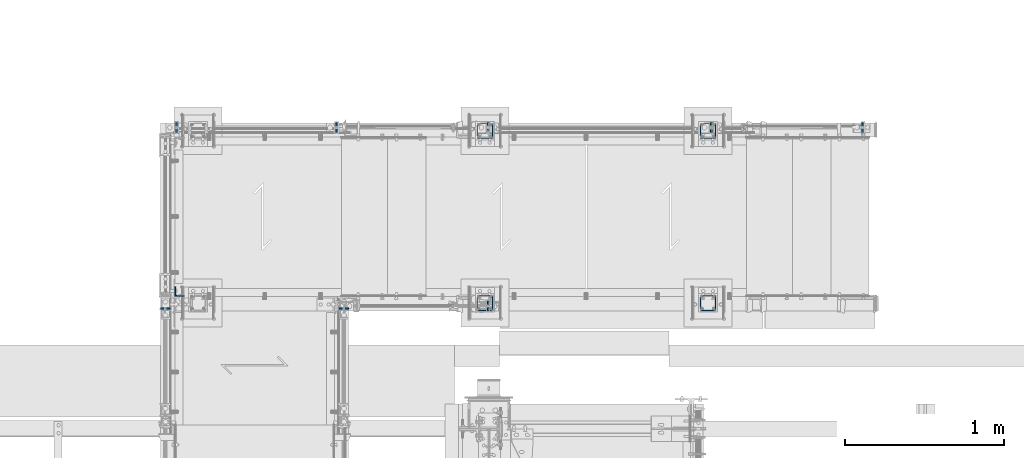
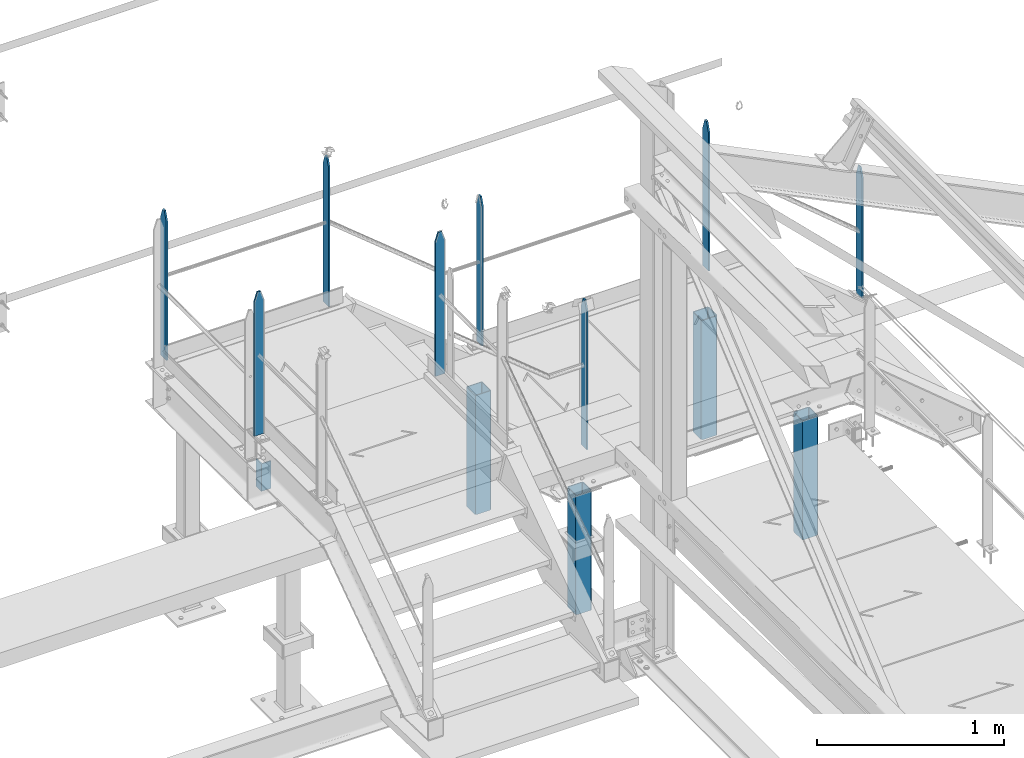
# One storey, part 40 of 496: 13 columns, 9 elements without a shape of their own.
"""IFC2X3 building model written with IfcOpenShell, lengths in millimetres."""

from ifc_helpers import new_model, si_unit, frame, origin_with_axes, origin_2d_with_axis, place, context, subcontext, project, spatial, rectangle, hollow_rectangle, l_section, extrude, clip, halfspace, material, type_object, element, aggregate, save


model = new_model("IFC2X3")

# Units and contexts
model_context = context("Model", 3, precision=1e-05, world=origin_with_axes())
body_context = subcontext(model_context, "Body", "Model", "MODEL_VIEW")
ifc_project = project(units=[si_unit("LENGTHUNIT", "METRE", prefix="MILLI"), si_unit("AREAUNIT", "SQUARE_METRE"), si_unit("VOLUMEUNIT", "CUBIC_METRE"), si_unit("MASSUNIT", "GRAM", prefix="KILO"), si_unit("TIMEUNIT", "SECOND"), si_unit("PLANEANGLEUNIT", "RADIAN"), si_unit("SOLIDANGLEUNIT", "STERADIAN"), si_unit("THERMODYNAMICTEMPERATUREUNIT", "DEGREE_CELSIUS"), si_unit("LUMINOUSINTENSITYUNIT", "LUMEN")], contexts=[model_context])

# Site, building, storey
site_placement = place(None, origin_with_axes())
site = spatial("IfcSite", under=ifc_project, at=site_placement, CompositionType="ELEMENT")
building_placement = place(site_placement, origin_with_axes())
building = spatial("IfcBuilding", under=site, at=building_placement, Name="Undefined", CompositionType="ELEMENT")
storey_placement = place(building_placement, origin_with_axes())
storey = spatial("IfcBuildingStorey", under=building, at=storey_placement, Name="Undefined", CompositionType="ELEMENT", Elevation=0.0)

# Assembly, column
assembly_1_placement = place(storey_placement, origin_with_axes())
assembly_1 = element("IfcElementAssembly", 1, at=assembly_1_placement, inside=storey, Name="MAIN COURANTE", AssemblyPlace="NOTDEFINED", PredefinedType="NOTDEFINED")
ifc_material = material(Name="Undefined/S235-E24")
column_type_1 = type_object("IfcColumnType", PredefinedType="NOTDEFINED")
column_1_placement = place(assembly_1_placement, frame((34275.0061849194, 15970.0000882977, 9087.59993922658), z_axis=(0.0, 0.0, -1.0), x_axis=(0.0, 1.0, 0.0)))
column_1 = element("IfcColumn", 2, at=column_1_placement, type_object=column_type_1, material=ifc_material, Name="MONTANT", context=body_context, shape_type="Clipping", body=[
    clip(clip(extrude(rectangle(XDim=10.0, YDim=60.0, at=origin_2d_with_axis()), frame((0.0, 0.0, 967.599998469686), z_axis=(0.0, 0.0, -1.0), x_axis=(0.0, 1.0, 0.0)), (0.0, 0.0, 1.0), 967.6), halfspace(frame((-30.0, 5.0, -120.0), z_axis=(0.948683298050514, 0.0, -0.316227766016838), x_axis=(0.0, -1.0, 0.0)), False)), halfspace(frame((-30.0, 5.0, 60.0), z_axis=(-0.948683298050514, 0.0, -0.316227766016838), x_axis=(0.0, -1.0, 0.0)), False)),
])
aggregate(assembly_1, [column_1])

# Assembly, columns
assembly_2_placement = place(storey_placement, origin_with_axes())
assembly_2 = element("IfcElementAssembly", 3, at=assembly_2_placement, inside=storey, Name="MAIN COURANTE", AssemblyPlace="NOTDEFINED", PredefinedType="NOTDEFINED")
column_2_placement = place(assembly_2_placement, frame((33325.0061849194, 17089.9938659712, 9677.59999847), z_axis=(0.0, 0.0, -1.0), x_axis=(0.0, -1.0, 0.0)))
column_2 = element("IfcColumn", 4, at=column_2_placement, type_object=column_type_1, material=ifc_material, Name="MONTANT", context=body_context, shape_type="Clipping", body=[
    clip(clip(extrude(rectangle(XDim=10.0, YDim=60.0, at=origin_2d_with_axis()), frame((0.0, 0.0, 967.599998469686), z_axis=(0.0, 0.0, -1.0), x_axis=(0.0, 1.0, 0.0)), (0.0, 0.0, 1.0), 967.6), halfspace(frame((-30.0, -5.0, -120.0), z_axis=(0.948683298050514, 0.0, -0.316227766016838), x_axis=(0.316227766016838, 0.0, 0.948683298050514)), False)), halfspace(frame((-30.0, -5.0, 60.0), z_axis=(-0.948683298050514, 0.0, -0.316227766016838), x_axis=(0.316227766016838, 0.0, -0.948683298050514)), False)),
])
column_3_placement = place(assembly_2_placement, frame((32319.9961849194, 17089.9938659712, 9677.59999847), z_axis=(0.0, 0.0, -1.0), x_axis=(0.0, -1.0, 0.0)))
column_3 = element("IfcColumn", 5, at=column_3_placement, type_object=column_type_1, material=ifc_material, Name="MONTANT", context=body_context, shape_type="Clipping", body=[
    clip(clip(extrude(rectangle(XDim=10.0, YDim=60.0, at=origin_2d_with_axis()), frame((0.0, 0.0, 967.599998469686), z_axis=(0.0, 0.0, -1.0), x_axis=(0.0, 1.0, 0.0)), (0.0, 0.0, 1.0), 967.6), halfspace(frame((-30.0, -5.0, -120.0), z_axis=(0.948683298050514, 0.0, -0.316227766016838), x_axis=(0.316227766016838, 0.0, 0.948683298050514)), False)), halfspace(frame((-30.0, -5.0, 60.0), z_axis=(-0.948683298050514, 0.0, -0.316227766016838), x_axis=(0.316227766016838, 0.0, -0.948683298050514)), False)),
])
column_4_placement = place(assembly_2_placement, frame((35675.0061849194, 17089.9938659712, 9087.59993922658), z_axis=(0.0, 0.0, -1.0), x_axis=(0.0, -1.0, 0.0)))
column_4 = element("IfcColumn", 6, at=column_4_placement, type_object=column_type_1, material=ifc_material, Name="MONTANT", context=body_context, shape_type="Clipping", body=[
    clip(clip(extrude(rectangle(XDim=10.0, YDim=60.0, at=origin_2d_with_axis()), frame((0.0, 0.0, 967.599939226584), z_axis=(0.0, 0.0, -1.0), x_axis=(0.0, 1.0, 0.0)), (0.0, 0.0, 1.0), 967.6), halfspace(frame((-30.0, -5.0, -120.0), z_axis=(0.948683298050514, 0.0, -0.316227766016838), x_axis=(0.316227766016838, 0.0, 0.948683298050514)), False)), halfspace(frame((-30.0, -5.0, 60.0), z_axis=(-0.948683298050514, 0.0, -0.316227766016838), x_axis=(0.316227766016838, 0.0, -0.948683298050514)), False)),
])
column_5_placement = place(assembly_2_placement, frame((34275.0061849194, 17089.9938659712, 9087.59993922658), z_axis=(0.0, 0.0, -1.0), x_axis=(0.0, -1.0, 0.0)))
column_5 = element("IfcColumn", 7, at=column_5_placement, type_object=column_type_1, material=ifc_material, Name="MONTANT", context=body_context, shape_type="Clipping", body=[
    clip(clip(extrude(rectangle(XDim=10.0, YDim=60.0, at=origin_2d_with_axis()), frame((0.0, 0.0, 967.599998469686), z_axis=(0.0, 0.0, -1.0), x_axis=(0.0, 1.0, 0.0)), (0.0, 0.0, 1.0), 967.6), halfspace(frame((-30.0, -5.0, -120.0), z_axis=(0.948683298050514, 0.0, -0.316227766016838), x_axis=(0.316227766016838, 0.0, 0.948683298050514)), False)), halfspace(frame((-30.0, -5.0, 60.0), z_axis=(-0.948683298050514, 0.0, -0.316227766016838), x_axis=(0.316227766016838, 0.0, -0.948683298050514)), False)),
])
column_6_placement = place(assembly_2_placement, frame((36625.0061849194, 17089.9938659712, 8458.13573617826), z_axis=(0.0, 0.0, -1.0), x_axis=(0.0, -1.0, 0.0)))
column_6 = element("IfcColumn", 8, at=column_6_placement, type_object=column_type_1, material=ifc_material, Name="MONTANT", context=body_context, shape_type="Clipping", body=[
    clip(clip(clip(clip(extrude(rectangle(XDim=10.0, YDim=60.0, at=origin_2d_with_axis()), frame((0.0, 0.0, 860.207207578189), z_axis=(0.0, 0.0, -1.0), x_axis=(0.0, 1.0, 0.0)), (0.0, 0.0, 1.0), 868.62), halfspace(frame((-30.0, -5.0, -120.0), z_axis=(0.948683298050514, 0.0, -0.316227766016838), x_axis=(0.316227766016838, 0.0, 0.948683298050514)), False)), halfspace(frame((-30.0, -5.0, 60.0), z_axis=(-0.948683298050514, 0.0, -0.316227766016838), x_axis=(0.316227766016838, 0.0, -0.948683298050514)), False)), halfspace(frame((0.0, -7.81419051645935, 858.302366962016), z_axis=(0.0, 0.64018439966452, 0.768221279597343), x_axis=(-1.0, 0.0, 0.0)), False)), halfspace(frame((0.0, -6.92990936078422, 5.77492361636723), z_axis=(0.0, 0.64018439966452, 0.768221279597343), x_axis=(-1.0, 0.0, 0.0)), True)),
])
aggregate(assembly_2, [column_2, column_3, column_4, column_5, column_6])

# Assembly, column
assembly_3_placement = place(storey_placement, origin_with_axes())
assembly_3 = element("IfcElementAssembly", 9, at=assembly_3_placement, inside=storey, Name="MAIN COURANTE", AssemblyPlace="NOTDEFINED", PredefinedType="NOTDEFINED")
column_7_placement = place(assembly_3_placement, frame((32249.9862112009, 15955.003622146, 9857.59999847), z_axis=(0.0, 0.0, -1.0), x_axis=(-0.99999999999782, -2.08799998896818e-06, 0.0)))
column_7 = element("IfcColumn", 10, at=column_7_placement, type_object=column_type_1, material=ifc_material, Name="MONTANT", context=body_context, shape_type="Clipping", body=[
    clip(clip(extrude(rectangle(XDim=10.0, YDim=60.0, at=origin_2d_with_axis()), frame((0.0, 0.0, 937.599998469999), z_axis=(0.0, 0.0, -1.0), x_axis=(0.0, 1.0, 0.0)), (0.0, 0.0, 1.0), 937.6), halfspace(frame((-30.0, 5.0, -119.999937359999), z_axis=(0.948683298048446, 1.98085072276202e-06, -0.316227766016837), x_axis=(-3.63797880701241e-15, -0.999999999980381, -6.26399999950979e-06)), False)), halfspace(frame((-30.0, 5.0, 60.0), z_axis=(-0.948683397048399, -1.98084886235393e-06, -0.316227469016822), x_axis=(-3.63797880701241e-15, -0.999999999980381, 6.26399999950979e-06)), False)),
])
aggregate(assembly_3, [column_7])

assembly_4_placement = place(storey_placement, origin_with_axes())
assembly_4 = element("IfcElementAssembly", 11, at=assembly_4_placement, inside=storey, Name="MAIN COURANTE", AssemblyPlace="NOTDEFINED", PredefinedType="NOTDEFINED")
column_8_placement = place(assembly_4_placement, frame((33369.9937887991, 15954.9996684868, 9857.59999847), z_axis=(0.0, 0.0, -1.0), x_axis=(0.999999999998558, -1.69800000185205e-06, 0.0)))
column_8 = element("IfcColumn", 12, at=column_8_placement, type_object=column_type_1, material=ifc_material, Name="MONTANT", context=body_context, shape_type="Clipping", body=[
    clip(clip(extrude(rectangle(XDim=10.0, YDim=60.0, at=origin_2d_with_axis()), frame((0.0, 0.0, 937.599998469999), z_axis=(0.0, 0.0, -1.0), x_axis=(0.0, 1.0, 0.0)), (0.0, 0.0, 1.0), 937.6), halfspace(frame((-29.9999999999927, -4.99999999999818, -119.999937359999), z_axis=(0.948683298048446, -1.98085071586376e-06, -0.316227766016837), x_axis=(0.316227766016838, 0.0, 0.948683298050514)), False)), halfspace(frame((-30.0, -5.0, 60.0), z_axis=(-0.948683298048225, 1.98099999943224e-06, -0.3162277660175), x_axis=(0.316227766016838, 0.0, -0.948683298050514)), False)),
])
aggregate(assembly_4, [column_8])

assembly_5_placement = place(storey_placement, origin_with_axes())
assembly_5 = element("IfcElementAssembly", 13, at=assembly_5_placement, inside=storey, AssemblyPlace="NOTDEFINED", PredefinedType="NOTDEFINED")
column_type_2 = type_object("IfcColumnType", PredefinedType="NOTDEFINED")
column_9_placement = place(assembly_5_placement, frame((34255.0000000001, 15989.9999136253, 7062.0), z_axis=(0.0, 0.0, 1.0), x_axis=(0.0, 1.0, 0.0)))
column_9 = element("IfcColumn", 14, at=column_9_placement, type_object=column_type_2, material=ifc_material, context=body_context, shape_type="SweptSolid", body=[
    extrude(hollow_rectangle(XDim=100.0, YDim=100.0, WallThickness=5.0, InnerFilletRadius=5.0, OuterFilletRadius=10.0, at=origin_2d_with_axis()), frame((0.0, 0.0, 780.000011607546), z_axis=(0.0, 0.0, -1.0), x_axis=(0.0, 1.0, 0.0)), (0.0, 0.0, 1.0), 780.0),
])
aggregate(assembly_5, [column_9])

assembly_6_placement = place(storey_placement, origin_with_axes())
assembly_6 = element("IfcElementAssembly", 15, at=assembly_6_placement, inside=storey, AssemblyPlace="NOTDEFINED", PredefinedType="NOTDEFINED")
column_10_placement = place(assembly_6_placement, frame((35655.0000000001, 15989.9999136253, 7062.0), z_axis=(0.0, 0.0, 1.0), x_axis=(0.0, 1.0, 0.0)))
column_10 = element("IfcColumn", 16, at=column_10_placement, type_object=column_type_2, material=ifc_material, context=body_context, shape_type="SweptSolid", body=[
    extrude(hollow_rectangle(XDim=100.0, YDim=100.0, WallThickness=5.0, InnerFilletRadius=5.0, OuterFilletRadius=10.0, at=origin_2d_with_axis()), frame((0.0, 0.0, 780.000011607546), z_axis=(0.0, 0.0, -1.0), x_axis=(0.0, 1.0, 0.0)), (0.0, 0.0, 1.0), 780.0),
])
aggregate(assembly_6, [column_10])

assembly_7_placement = place(storey_placement, origin_with_axes())
assembly_7 = element("IfcElementAssembly", 17, at=assembly_7_placement, inside=storey, AssemblyPlace="NOTDEFINED", PredefinedType="NOTDEFINED")
column_11_placement = place(assembly_7_placement, frame((34255.0000000001, 17069.9996684749, 7062.0), z_axis=(0.0, 0.0, 1.0), x_axis=(0.0, -1.0, 0.0)))
column_11 = element("IfcColumn", 18, at=column_11_placement, type_object=column_type_2, material=ifc_material, context=body_context, shape_type="SweptSolid", body=[
    extrude(hollow_rectangle(XDim=100.0, YDim=100.0, WallThickness=5.0, InnerFilletRadius=5.0, OuterFilletRadius=10.0, at=origin_2d_with_axis()), frame((0.0, 0.0, 780.000011607546), z_axis=(0.0, 0.0, -1.0), x_axis=(0.0, 1.0, 0.0)), (0.0, 0.0, 1.0), 780.0),
])
aggregate(assembly_7, [column_11])

assembly_8_placement = place(storey_placement, origin_with_axes())
assembly_8 = element("IfcElementAssembly", 19, at=assembly_8_placement, inside=storey, AssemblyPlace="NOTDEFINED", PredefinedType="NOTDEFINED")
column_12_placement = place(assembly_8_placement, frame((35655.0000000001, 17069.9996684749, 7062.0), z_axis=(0.0, 0.0, 1.0), x_axis=(0.0, -1.0, 0.0)))
column_12 = element("IfcColumn", 20, at=column_12_placement, type_object=column_type_2, material=ifc_material, context=body_context, shape_type="SweptSolid", body=[
    extrude(hollow_rectangle(XDim=100.0, YDim=100.0, WallThickness=5.0, InnerFilletRadius=5.0, OuterFilletRadius=10.0, at=origin_2d_with_axis()), frame((0.0, 0.0, 780.000011607546), z_axis=(0.0, 0.0, -1.0), x_axis=(0.0, 1.0, 0.0)), (0.0, 0.0, 1.0), 780.0),
])
aggregate(assembly_8, [column_12])

assembly_9_placement = place(storey_placement, origin_with_axes())
assembly_9 = element("IfcElementAssembly", 21, at=assembly_9_placement, inside=storey, AssemblyPlace="NOTDEFINED", PredefinedType="NOTDEFINED")
column_type_3 = type_object("IfcColumnType", PredefinedType="NOTDEFINED")
column_13_placement = place(assembly_9_placement, frame((32340.0061849181, 16059.9933714878, 8480.0), z_axis=(0.0, 0.0, 1.0), x_axis=(1.0, 0.0, 0.0)))
column_13 = element("IfcColumn", 22, at=column_13_placement, type_object=column_type_3, material=ifc_material, context=body_context, shape_type="SweptSolid", body=[
    extrude(l_section(Depth=60.0, Width=60.0, Thickness=6.0, FilletRadius=8.0, EdgeRadius=4.0, at=origin_2d_with_axis()), frame((0.0, 0.0, 180.0), z_axis=(0.0, 0.0, -1.0), x_axis=(0.0, 1.0, 0.0)), (0.0, 0.0, 1.0), 180.0),
])
aggregate(assembly_9, [column_13])

save(model, "model.ifc")
